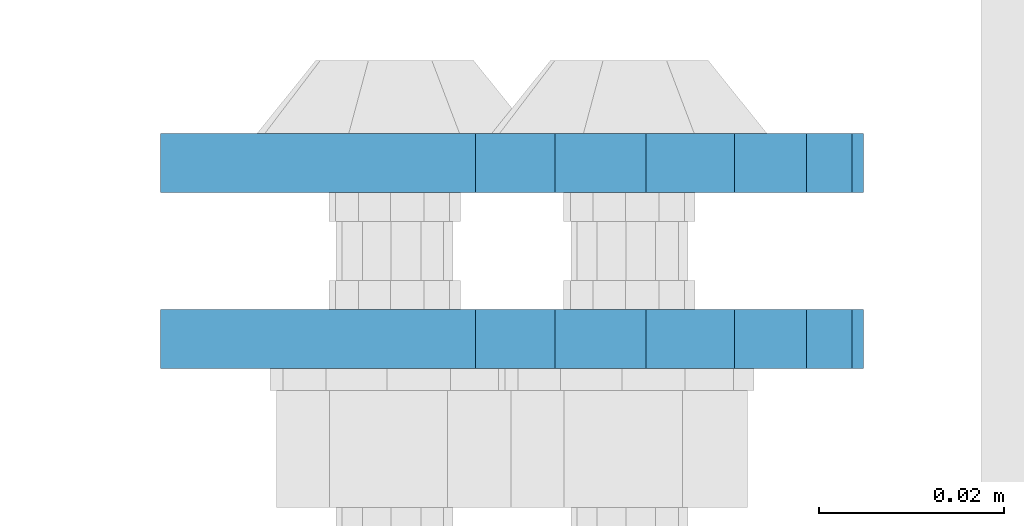
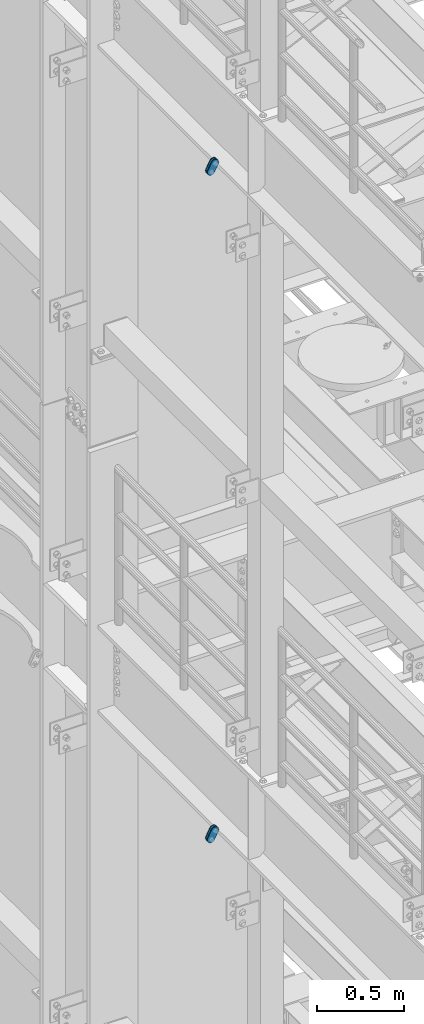
# One storey, part 1531 of 1876: 4 plates, 4 elements without a shape of their own.
"""IFC2X3 building model written with IfcOpenShell, lengths in millimetres."""

from ifc_helpers import new_model, si_unit, frame, origin_with_axes, place, context, subcontext, project, spatial, faceted_brep, material, type_object, element, aggregate, save


model = new_model("IFC2X3")

# Units and contexts
model_context = context("Model", 3, precision=1e-05, world=origin_with_axes())
body_context = subcontext(model_context, "Body", "Model", "MODEL_VIEW")
ifc_project = project(units=[si_unit("LENGTHUNIT", "METRE", prefix="MILLI"), si_unit("AREAUNIT", "SQUARE_METRE"), si_unit("VOLUMEUNIT", "CUBIC_METRE"), si_unit("MASSUNIT", "GRAM", prefix="KILO"), si_unit("TIMEUNIT", "SECOND"), si_unit("PLANEANGLEUNIT", "RADIAN"), si_unit("SOLIDANGLEUNIT", "STERADIAN"), si_unit("THERMODYNAMICTEMPERATUREUNIT", "DEGREE_CELSIUS"), si_unit("LUMINOUSINTENSITYUNIT", "LUMEN")], contexts=[model_context])

# Site, building, storey
site_placement = place(None, origin_with_axes())
site = spatial("IfcSite", under=ifc_project, at=site_placement, CompositionType="ELEMENT")
building_placement = place(site_placement, origin_with_axes())
building = spatial("IfcBuilding", under=site, at=building_placement, Name="Undefined", CompositionType="ELEMENT")
storey_placement = place(building_placement, origin_with_axes())
storey = spatial("IfcBuildingStorey", under=building, at=storey_placement, Name="Undefined", CompositionType="ELEMENT", Elevation=0.0)

# Assembly, plate
assembly_1_placement = place(storey_placement, origin_with_axes())
assembly_1 = element("IfcElementAssembly", 1, at=assembly_1_placement, inside=storey, Name="PLATE", AssemblyPlace="NOTDEFINED", PredefinedType="RIGID_FRAME")
ifc_material = material(Name="STEEL/A36")
plate_type = type_object("IfcPlateType", PredefinedType="NOTDEFINED")
plate_1_placement = place(assembly_1_placement, frame((-354.259224851122, -517.524994679405, 17725.1776774809), z_axis=(0.894427191199916, 0.0, -0.447213595099958), x_axis=(-0.447213595099961, 6.99999707257306e-09, -0.894427191199915)))
plate_1 = element("IfcPlate", 2, at=plate_1_placement, type_object=plate_type, material=ifc_material, Name="PLATE", context=body_context, shape_type="Brep", body=[
    faceted_brep([(-8.59611645864788e-07, -3.17499999999654, 25.3999987589127), (1.93345873884391, -3.17499999999382, 35.1201580589886), (1.93345873884391, 3.17500000000564, 35.1201580589886), (-8.59611645864788e-07, 3.17500000000382, 25.3999987589132), (7.43948648259902, -3.17499999999109, 43.3605112870105), (7.43948648259902, 3.17500000000928, 43.3605112870105), (15.6798395242777, -3.17499999998654, 48.8665393096448), (15.6798395242777, 3.17500000001382, 48.8665393096448), (25.3999987589095, -3.17499999998199, 50.7999992370592), (25.3999987589095, 3.17500000001837, 50.7999992370592), (82.196130752618, -3.17499999998381, 50.7999992370605), (82.196130752618, 3.17500000001655, 50.7999992370642), (91.9162897887145, -3.17499999997926, 48.8665393918873), (91.9162897887145, 3.1750000000211, 48.8665393918909), (100.156642725027, -3.17499999997472, 43.3605115909359), (100.156642725027, 3.17500000002565, 43.3605115909395), (105.662670525982, -3.17499999997108, 35.1201586546285), (105.662670525986, 3.17500000002929, 35.1201586546358), (107.596130371159, -3.17499999996744, 25.3999996185757), (107.596130371159, 3.17500000003292, 25.3999996185794), (105.662670525981, -3.17499999996471, 15.6798405824902), (105.662670525981, 3.17500000003565, 15.6798405824939), (100.156642725024, -3.17499999996471, 7.43948764618654), (100.156642725025, 3.17500000003565, 7.43948764619017), (91.9162897887127, -3.17499999996562, 1.93345984522784), (91.9162897887127, 3.17500000003474, 1.93345984523148), (82.196130752618, -3.17499999996835, 4.54747350886464e-11), (82.196130752618, 3.1750000000311, 4.91127138957381e-11), (25.399998758905, -3.17499999999018, -8.64019966684282e-12), (25.399998758905, 3.17500000001019, -8.64019966684282e-12), (15.679839921364, -3.17499999999382, 1.9334597629304), (15.679839921364, 3.17500000000655, 1.9334597629304), (7.43948709043525, -3.17499999999654, 7.43948734220839), (7.43948709043525, 3.17500000000382, 7.43948734220885), (1.93345923228208, -3.17499999999654, 15.6798399868012), (1.93345923228208, 3.17500000000291, 15.6798399868012)], [[[0, 1, 2, 3]], [[1, 4, 5, 2]], [[4, 6, 7, 5]], [[6, 8, 9, 7]], [[8, 10, 11, 9]], [[10, 12, 13, 11]], [[12, 14, 15, 13]], [[14, 16, 17, 15]], [[16, 18, 19, 17]], [[18, 20, 21, 19]], [[20, 22, 23, 21]], [[22, 24, 25, 23]], [[24, 26, 27, 25]], [[26, 28, 29, 27]], [[28, 30, 31, 29]], [[30, 32, 33, 31]], [[32, 34, 35, 33]], [[34, 0, 3, 35]], [[5, 7, 9, 11, 13, 15, 17, 19, 21, 23, 25, 27, 29, 31, 33, 35, 3, 2]], [[34, 32, 30, 28, 26, 24, 22, 20, 18, 16, 14, 12, 10, 8, 6, 4, 1, 0]]]),
])
aggregate(assembly_1, [plate_1])

assembly_2_placement = place(storey_placement, origin_with_axes())
assembly_2 = element("IfcElementAssembly", 3, at=assembly_2_placement, inside=storey, Name="PLATE", AssemblyPlace="NOTDEFINED", PredefinedType="RIGID_FRAME")
plate_2_placement = place(assembly_2_placement, frame((-354.259224851122, -498.463798374725, 17725.1776774809), z_axis=(0.894427191199916, 0.0, -0.447213595099958), x_axis=(-0.447213595099961, 6.99999707257306e-09, -0.894427191199915)))
plate_2 = element("IfcPlate", 4, at=plate_2_placement, type_object=plate_type, material=ifc_material, Name="PLATE", context=body_context, shape_type="Brep", body=[
    faceted_brep([(-8.59611645864788e-07, -3.17499999999654, 25.3999987589127), (1.93345873884391, -3.17499999999382, 35.1201580589886), (1.93345873884391, 3.17500000000564, 35.1201580589886), (-8.59611645864788e-07, 3.17500000000382, 25.3999987589132), (7.43948648259902, -3.17499999999109, 43.3605112870105), (7.43948648259902, 3.17500000000928, 43.3605112870105), (15.6798395242777, -3.17499999998654, 48.8665393096448), (15.6798395242777, 3.17500000001382, 48.8665393096448), (25.3999987589095, -3.17499999998199, 50.7999992370592), (25.3999987589095, 3.17500000001837, 50.7999992370592), (82.196130752618, -3.17499999998381, 50.7999992370605), (82.196130752618, 3.17500000001655, 50.7999992370642), (91.9162897887145, -3.17499999997926, 48.8665393918873), (91.9162897887145, 3.1750000000211, 48.8665393918909), (100.156642725027, -3.17499999997472, 43.3605115909359), (100.156642725027, 3.17500000002565, 43.3605115909395), (105.662670525982, -3.17499999997108, 35.1201586546285), (105.662670525986, 3.17500000002929, 35.1201586546358), (107.596130371159, -3.17499999996744, 25.3999996185757), (107.596130371159, 3.17500000003292, 25.3999996185794), (105.662670525981, -3.17499999996471, 15.6798405824902), (105.662670525981, 3.17500000003565, 15.6798405824939), (100.156642725024, -3.17499999996471, 7.43948764618654), (100.156642725025, 3.17500000003565, 7.43948764619017), (91.9162897887127, -3.17499999996562, 1.93345984522784), (91.9162897887127, 3.17500000003474, 1.93345984523148), (82.196130752618, -3.17499999996835, 4.54747350886464e-11), (82.196130752618, 3.1750000000311, 4.91127138957381e-11), (25.399998758905, -3.17499999999018, -8.64019966684282e-12), (25.399998758905, 3.17500000001019, -8.64019966684282e-12), (15.679839921364, -3.17499999999382, 1.9334597629304), (15.679839921364, 3.17500000000655, 1.9334597629304), (7.43948709043525, -3.17499999999654, 7.43948734220839), (7.43948709043525, 3.17500000000382, 7.43948734220885), (1.93345923228208, -3.17499999999654, 15.6798399868012), (1.93345923228208, 3.17500000000291, 15.6798399868012)], [[[0, 1, 2, 3]], [[1, 4, 5, 2]], [[4, 6, 7, 5]], [[6, 8, 9, 7]], [[8, 10, 11, 9]], [[10, 12, 13, 11]], [[12, 14, 15, 13]], [[14, 16, 17, 15]], [[16, 18, 19, 17]], [[18, 20, 21, 19]], [[20, 22, 23, 21]], [[22, 24, 25, 23]], [[24, 26, 27, 25]], [[26, 28, 29, 27]], [[28, 30, 31, 29]], [[30, 32, 33, 31]], [[32, 34, 35, 33]], [[34, 0, 3, 35]], [[5, 7, 9, 11, 13, 15, 17, 19, 21, 23, 25, 27, 29, 31, 33, 35, 3, 2]], [[34, 32, 30, 28, 26, 24, 22, 20, 18, 16, 14, 12, 10, 8, 6, 4, 1, 0]]]),
])
aggregate(assembly_2, [plate_2])

assembly_3_placement = place(storey_placement, origin_with_axes())
assembly_3 = element("IfcElementAssembly", 5, at=assembly_3_placement, inside=storey, Name="PLATE", AssemblyPlace="NOTDEFINED", PredefinedType="RIGID_FRAME")
plate_3_placement = place(assembly_3_placement, frame((-354.259224851122, -517.524994679405, 13038.8776774809), z_axis=(0.894427191199916, 0.0, -0.447213595099958), x_axis=(-0.447213595099961, 6.99999707257306e-09, -0.894427191199915)))
plate_3 = element("IfcPlate", 6, at=plate_3_placement, type_object=plate_type, material=ifc_material, Name="PLATE", context=body_context, shape_type="Brep", body=[
    faceted_brep([(-8.59611645864788e-07, -3.17499999999654, 25.3999987589127), (1.93345873884391, -3.17499999999382, 35.1201580589886), (1.93345873884391, 3.17500000000564, 35.1201580589886), (-8.59611645864788e-07, 3.17500000000382, 25.3999987589132), (7.43948648259902, -3.17499999999109, 43.3605112870105), (7.43948648259902, 3.17500000000928, 43.3605112870105), (15.6798395242777, -3.17499999998654, 48.8665393096448), (15.6798395242777, 3.17500000001382, 48.8665393096448), (25.3999987589095, -3.17499999998199, 50.7999992370592), (25.3999987589095, 3.17500000001837, 50.7999992370592), (82.196130752618, -3.17499999998381, 50.7999992370605), (82.196130752618, 3.17500000001655, 50.7999992370642), (91.9162897887145, -3.17499999997926, 48.8665393918873), (91.9162897887145, 3.1750000000211, 48.8665393918909), (100.156642725027, -3.17499999997472, 43.3605115909359), (100.156642725027, 3.17500000002565, 43.3605115909395), (105.662670525982, -3.17499999997108, 35.1201586546285), (105.662670525986, 3.17500000002929, 35.1201586546358), (107.596130371159, -3.17499999996744, 25.3999996185757), (107.596130371159, 3.17500000003292, 25.3999996185794), (105.662670525981, -3.17499999996471, 15.6798405824902), (105.662670525981, 3.17500000003565, 15.6798405824939), (100.156642725024, -3.17499999996471, 7.43948764618654), (100.156642725025, 3.17500000003565, 7.43948764619017), (91.9162897887127, -3.17499999996562, 1.93345984522784), (91.9162897887127, 3.17500000003474, 1.93345984523148), (82.196130752618, -3.17499999996835, 4.54747350886464e-11), (82.196130752618, 3.1750000000311, 4.91127138957381e-11), (25.399998758905, -3.17499999999018, -8.64019966684282e-12), (25.399998758905, 3.17500000001019, -8.64019966684282e-12), (15.679839921364, -3.17499999999382, 1.9334597629304), (15.679839921364, 3.17500000000655, 1.9334597629304), (7.43948709043525, -3.17499999999654, 7.43948734220839), (7.43948709043525, 3.17500000000382, 7.43948734220885), (1.93345923228208, -3.17499999999654, 15.6798399868012), (1.93345923228208, 3.17500000000291, 15.6798399868012)], [[[0, 1, 2, 3]], [[1, 4, 5, 2]], [[4, 6, 7, 5]], [[6, 8, 9, 7]], [[8, 10, 11, 9]], [[10, 12, 13, 11]], [[12, 14, 15, 13]], [[14, 16, 17, 15]], [[16, 18, 19, 17]], [[18, 20, 21, 19]], [[20, 22, 23, 21]], [[22, 24, 25, 23]], [[24, 26, 27, 25]], [[26, 28, 29, 27]], [[28, 30, 31, 29]], [[30, 32, 33, 31]], [[32, 34, 35, 33]], [[34, 0, 3, 35]], [[5, 7, 9, 11, 13, 15, 17, 19, 21, 23, 25, 27, 29, 31, 33, 35, 3, 2]], [[34, 32, 30, 28, 26, 24, 22, 20, 18, 16, 14, 12, 10, 8, 6, 4, 1, 0]]]),
])
aggregate(assembly_3, [plate_3])

assembly_4_placement = place(storey_placement, origin_with_axes())
assembly_4 = element("IfcElementAssembly", 7, at=assembly_4_placement, inside=storey, Name="PLATE", AssemblyPlace="NOTDEFINED", PredefinedType="RIGID_FRAME")
plate_4_placement = place(assembly_4_placement, frame((-354.259224851122, -498.463798374725, 13038.8776774809), z_axis=(0.894427191199916, 0.0, -0.447213595099958), x_axis=(-0.447213595099961, 6.99999707257306e-09, -0.894427191199915)))
plate_4 = element("IfcPlate", 8, at=plate_4_placement, type_object=plate_type, material=ifc_material, Name="PLATE", context=body_context, shape_type="Brep", body=[
    faceted_brep([(-8.59611645864788e-07, -3.17499999999654, 25.3999987589127), (1.93345873884391, -3.17499999999382, 35.1201580589886), (1.93345873884391, 3.17500000000564, 35.1201580589886), (-8.59611645864788e-07, 3.17500000000382, 25.3999987589132), (7.43948648259902, -3.17499999999109, 43.3605112870105), (7.43948648259902, 3.17500000000928, 43.3605112870105), (15.6798395242777, -3.17499999998654, 48.8665393096448), (15.6798395242777, 3.17500000001382, 48.8665393096448), (25.3999987589095, -3.17499999998199, 50.7999992370592), (25.3999987589095, 3.17500000001837, 50.7999992370592), (82.196130752618, -3.17499999998381, 50.7999992370605), (82.196130752618, 3.17500000001655, 50.7999992370642), (91.9162897887145, -3.17499999997926, 48.8665393918873), (91.9162897887145, 3.1750000000211, 48.8665393918909), (100.156642725027, -3.17499999997472, 43.3605115909359), (100.156642725027, 3.17500000002565, 43.3605115909395), (105.662670525982, -3.17499999997108, 35.1201586546285), (105.662670525986, 3.17500000002929, 35.1201586546358), (107.596130371159, -3.17499999996744, 25.3999996185757), (107.596130371159, 3.17500000003292, 25.3999996185794), (105.662670525981, -3.17499999996471, 15.6798405824902), (105.662670525981, 3.17500000003565, 15.6798405824939), (100.156642725024, -3.17499999996471, 7.43948764618654), (100.156642725025, 3.17500000003565, 7.43948764619017), (91.9162897887127, -3.17499999996562, 1.93345984522784), (91.9162897887127, 3.17500000003474, 1.93345984523148), (82.196130752618, -3.17499999996835, 4.54747350886464e-11), (82.196130752618, 3.1750000000311, 4.91127138957381e-11), (25.399998758905, -3.17499999999018, -8.64019966684282e-12), (25.399998758905, 3.17500000001019, -8.64019966684282e-12), (15.679839921364, -3.17499999999382, 1.9334597629304), (15.679839921364, 3.17500000000655, 1.9334597629304), (7.43948709043525, -3.17499999999654, 7.43948734220839), (7.43948709043525, 3.17500000000382, 7.43948734220885), (1.93345923228208, -3.17499999999654, 15.6798399868012), (1.93345923228208, 3.17500000000291, 15.6798399868012)], [[[0, 1, 2, 3]], [[1, 4, 5, 2]], [[4, 6, 7, 5]], [[6, 8, 9, 7]], [[8, 10, 11, 9]], [[10, 12, 13, 11]], [[12, 14, 15, 13]], [[14, 16, 17, 15]], [[16, 18, 19, 17]], [[18, 20, 21, 19]], [[20, 22, 23, 21]], [[22, 24, 25, 23]], [[24, 26, 27, 25]], [[26, 28, 29, 27]], [[28, 30, 31, 29]], [[30, 32, 33, 31]], [[32, 34, 35, 33]], [[34, 0, 3, 35]], [[5, 7, 9, 11, 13, 15, 17, 19, 21, 23, 25, 27, 29, 31, 33, 35, 3, 2]], [[34, 32, 30, 28, 26, 24, 22, 20, 18, 16, 14, 12, 10, 8, 6, 4, 1, 0]]]),
])
aggregate(assembly_4, [plate_4])

save(model, "model.ifc")
